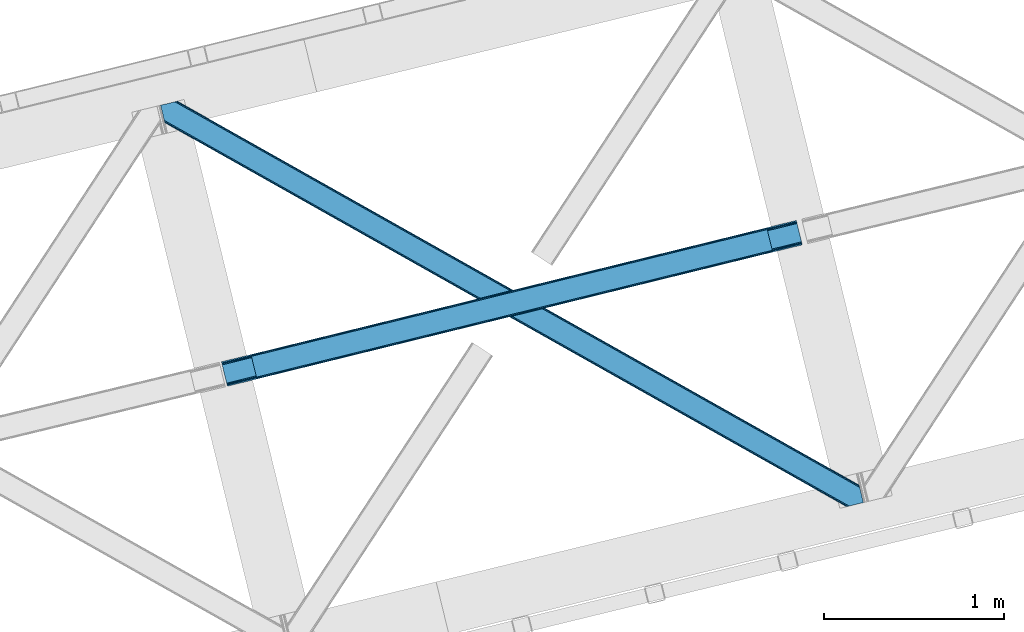
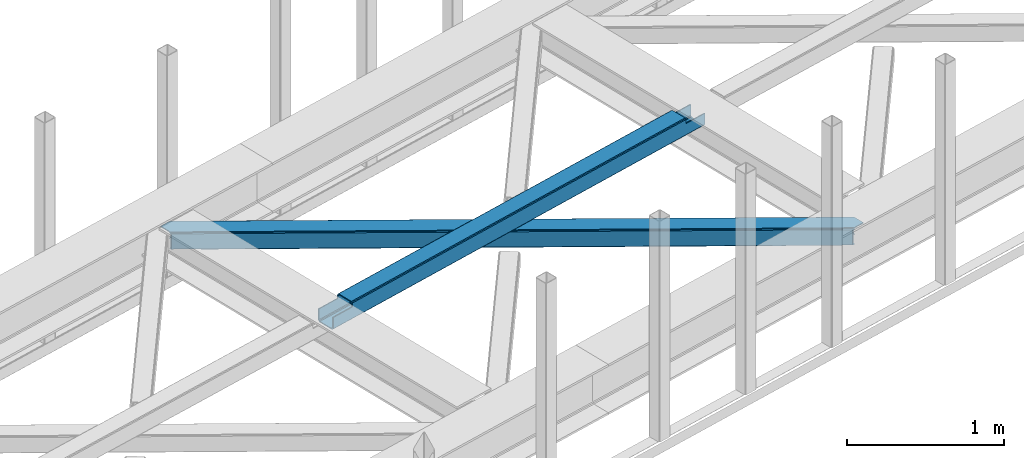
# One storey, part 30 of 66: 1 beam, 1 member.
"""IFC4 building model written with IfcOpenShell, lengths in millimetres."""

from ifc_helpers import new_model, entity, si_unit, converted_unit, derived_unit, direction, frame, origin, place, context, subcontext, project, spatial, triangles, polygons, material, type_object, element, save


model = new_model("IFC4")

# Units and contexts
model_context = context("Model", 3, precision=0.01, world=origin(), true_north=direction((6.12303176911189e-17, 1.0)))
plan_context = context("Plan", 3, precision=0.01, world=origin(), true_north=direction((6.12303176911189e-17, 1.0)))
body_context = subcontext(model_context, "Body", "Model", "MODEL_VIEW")
ifc_project = project(units=[si_unit("LENGTHUNIT", "METRE", prefix="MILLI"), si_unit("AREAUNIT", "SQUARE_METRE"), si_unit("VOLUMEUNIT", "CUBIC_METRE"), converted_unit("PLANEANGLEUNIT", "DEGREE", entity("IfcRatioMeasure", 0.0174532925199433), si_unit("PLANEANGLEUNIT", "RADIAN"), dimensions=[0, 0, 0, 0, 0, 0, 0]), si_unit("MASSUNIT", "GRAM", prefix="KILO"), derived_unit("MASSDENSITYUNIT", [(si_unit("MASSUNIT", "GRAM", prefix="KILO"), 1), (si_unit("LENGTHUNIT", "METRE"), -3)]), derived_unit("MOMENTOFINERTIAUNIT", [(si_unit("LENGTHUNIT", "METRE"), 4)]), si_unit("TIMEUNIT", "SECOND"), si_unit("FREQUENCYUNIT", "HERTZ"), si_unit("THERMODYNAMICTEMPERATUREUNIT", "DEGREE_CELSIUS"), derived_unit("THERMALTRANSMITTANCEUNIT", [(si_unit("MASSUNIT", "GRAM", prefix="KILO"), 1), (si_unit("THERMODYNAMICTEMPERATUREUNIT", "KELVIN"), -1), (si_unit("TIMEUNIT", "SECOND"), -3)]), derived_unit("VOLUMETRICFLOWRATEUNIT", [(si_unit("LENGTHUNIT", "METRE"), 3), (si_unit("TIMEUNIT", "SECOND"), -1)]), derived_unit("MASSFLOWRATEUNIT", [(si_unit("MASSUNIT", "GRAM", prefix="KILO"), 1), (si_unit("TIMEUNIT", "SECOND"), -1)]), derived_unit("ROTATIONALFREQUENCYUNIT", [(si_unit("TIMEUNIT", "SECOND"), -1)]), si_unit("ELECTRICCURRENTUNIT", "AMPERE"), si_unit("ELECTRICVOLTAGEUNIT", "VOLT"), si_unit("POWERUNIT", "WATT"), si_unit("FORCEUNIT", "NEWTON", prefix="KILO"), si_unit("ILLUMINANCEUNIT", "LUX"), si_unit("LUMINOUSFLUXUNIT", "LUMEN"), si_unit("LUMINOUSINTENSITYUNIT", "CANDELA"), derived_unit("USERDEFINED", [(si_unit("MASSUNIT", "GRAM", prefix="KILO"), -1), (si_unit("LENGTHUNIT", "METRE"), -2), (si_unit("TIMEUNIT", "SECOND"), 3), (si_unit("LUMINOUSFLUXUNIT", "LUMEN"), 1)]), derived_unit("LINEARVELOCITYUNIT", [(si_unit("LENGTHUNIT", "METRE"), 1), (si_unit("TIMEUNIT", "SECOND"), -1)]), si_unit("PRESSUREUNIT", "PASCAL"), derived_unit("USERDEFINED", [(si_unit("LENGTHUNIT", "METRE"), -2), (si_unit("MASSUNIT", "GRAM", prefix="KILO"), 1), (si_unit("TIMEUNIT", "SECOND"), -2)]), derived_unit("LINEARFORCEUNIT", [(si_unit("MASSUNIT", "GRAM", prefix="KILO"), 1), (si_unit("LENGTHUNIT", "METRE"), 1), (si_unit("TIMEUNIT", "SECOND"), -2), (si_unit("LENGTHUNIT", "METRE"), -1)]), derived_unit("PLANARFORCEUNIT", [(si_unit("MASSUNIT", "GRAM", prefix="KILO"), 1), (si_unit("LENGTHUNIT", "METRE"), 1), (si_unit("TIMEUNIT", "SECOND"), -2), (si_unit("LENGTHUNIT", "METRE"), -2)])], contexts=[model_context, plan_context])

# Site, building, storey
site_placement = place(None, origin())
site = spatial("IfcSite", under=ifc_project, at=site_placement, CompositionType="ELEMENT")
building_placement = place(site_placement, origin())
building = spatial("IfcBuilding", under=site, at=building_placement, CompositionType="ELEMENT")
storey_placement = place(building_placement, frame((0.0, 0.0, 19800.0)))
storey = spatial("IfcBuildingStorey", under=building, at=storey_placement, Name="06", CompositionType="ELEMENT", Elevation=19800.0)

# Beam
ifc_material = material(Name="Metal painted (White)")
beam_type = type_object("IfcBeamType", PredefinedType="BEAM")
beam_placement = place(storey_placement, frame((-42582.6, 8753.05, 3967.02)))
element("IfcBeam", 1, at=beam_placement, inside=storey, type_object=beam_type, material=ifc_material, ObjectType="Steel Beam", PredefinedType="BEAM", context=body_context, shape_type="Tessellation", body=[
    polygons([(195.608367476555, 47.1603367907862, 116.426112013184), (195.292888840642, 48.4545519431655, 123.123071565755), (3059.93715946748, 752.952673698146, 122.247211281438), (3060.2526381034, 751.658458545759, 115.550251728867), (194.394481695369, 52.1401648754784, 128.800478116566), (3059.03875232221, 756.63828663046, 127.92461783224), (193.049920384546, 57.6560744289323, 132.593997984055), (3057.69419101138, 762.154196183919, 131.718137699738), (191.463902179238, 64.1625333758854, 133.926102156763), (3056.10817280608, 768.660655130851, 133.050241872438), (169.91268263321, 152.573955618372, 133.926046892466), (3034.55695326005, 857.072077373337, 133.05018660814), (168.326664427911, 159.080414565288, 132.593934585632), (3032.97093505476, 863.578536320267, 131.718074301311), (166.982103117088, 164.596324118746, 128.800407822355), (3031.62637374393, 869.094445873725, 127.924547538033), (166.083695971823, 168.281937051061, 123.12299666394), (3030.72796659867, 872.78005880604, 122.247136379614), (165.768217335893, 169.576152203463, 116.426035493392), (3030.41248796274, 874.074273958432, 115.550175209066), (3028.75470184381, 880.875152592466, 100.498256633611), (3028.75470184381, 880.875152592468, 122.550171266493), (3029.07018047973, 879.580937440089, 129.24713243705), (3029.968587625, 875.895324507774, 134.924543595464), (3031.31314893582, 870.379414954318, 138.718070358737), (3032.89916714112, 863.872956007376, 140.050182665567), (3057.76595892501, 761.859776496813, 140.050246432065), (3059.3519771303, 755.353317549901, 138.718142259361), (3060.69653844113, 749.837407996445, 134.924622391867), (3061.59494558639, 746.151795064129, 129.247215841061), (3061.91042422235, 744.857579911637, 122.55025628849), (3061.91042422232, 744.857579911717, 100.498256633611), (3060.2526381034, 751.658458545755, 100.498256633611), (3030.41248796274, 874.074273958429, 100.498256633611), (165.768217335893, 169.576152203463, 101.478032742183), (195.608367476546, 47.1603367907873, 101.478032742183), (197.266153595643, 40.3594581560808, 101.478032742183), (197.266153595478, 40.3594581567511, 123.426116572816), (196.950674959548, 41.6536733091445, 130.123076125387), (196.052267814283, 45.3392862414595, 135.800482676189), (194.707706503452, 50.8551957949178, 139.594002543682), (193.121688298162, 57.361654741847, 140.926106716386), (168.254896514278, 159.374834252409, 140.926042949888), (166.668878308987, 165.881293199339, 139.593930643059), (165.324316998156, 171.397202752797, 135.800403879781), (164.425909852882, 175.082815685111, 130.122992721366), (164.110431216969, 176.377030837501, 123.426031550818), (164.110431216961, 176.377030837499, 101.478032742183), (3224.36306932035, 792.017916694966, 99.4982566336028), (3224.36306932034, 792.017916694964, 24.5000712229983), (31.4979362596031, 6.80087864157621, 25.4762844973403), (31.4979362596031, 6.80087864157838, 100.478032742175), (194.637299836219, 46.9215234289606, 100.478032742183), (1.65778611894061, 129.216694054251, 25.4762079775439), (3194.52291917968, 914.433732107637, 24.4999947032018), (3194.52291917969, 914.43373210764, 99.4982566336028), (3031.38355560307, 874.313087320258, 99.4982566336115), (1.65778611894061, 129.216694054253, 100.478032742179), (3226.02085543916, 785.217038061375, 17.5000751655718), (3226.02085543927, 785.217038060912, 99.4982566336028), (3062.88149186268, 745.096393273461, 99.4982566336071), (33.1557223796959, 2.71258215889247e-09, 100.478032742175), (33.1557223787603, 6.59790941881511e-09, 18.4762884399095), (3192.86513306077, 921.234610741677, 99.4982566336028), (3192.86513306076, 921.234610741675, 17.4999901435748), (1.73258740687743e-11, 136.017572688288, 18.4762034179168), (1.73258740687743e-11, 136.017572688289, 100.478032742175), (163.139363576634, 176.138217475671, 100.478032742183), (3061.22370574374, 751.897271907586, 99.4982566336028), (3029.72576948415, 881.113965954297, 99.4982566336071), (3194.83839781561, 913.139516955241, 17.8030351506349), (3195.73680496087, 909.453904022926, 12.1256285998286), (3197.0813662717, 903.93799446947, 8.33210873233546), (3198.66738447699, 897.43153552254, 7.00000455963569), (3220.21860402303, 809.020113280054, 7.00005982392856), (3221.80462222832, 802.513654333124, 8.33217213075803), (3223.14918353915, 796.997744779667, 12.1256988940357), (3224.04759068442, 793.31213184735, 17.8031100524503), (3225.70537680334, 786.511253213297, 10.8031139950195), (3224.80696965809, 790.19686614561, 5.12570283660054), (3223.46240834725, 795.712775699067, 1.33217607332724), (3221.87639014196, 802.219234646016, 6.37665021031353e-05), (3197.00959835807, 904.232414156576, 4.33146851719357e-12), (3195.42358015278, 910.738873103494, 1.3321041727041), (3194.07901884195, 916.254782656952, 5.12562404019723), (3193.18061169669, 919.940395589265, 10.8030305909992), (196.295085955143, 40.1206447949233, 100.478032742179), (164.797149695557, 169.337338841635, 100.478032742179), (27.3534709622775, 23.8030752266689, 7.97627309827059), (28.9394891675764, 17.2966162797201, 9.30838540509573), (30.2840504784081, 11.780706726263, 13.101912168369), (31.1824576236816, 8.09509379395009, 18.7793233267793), (1.97326475486207, 127.922478901843, 18.779248424964), (2.87167190013556, 124.236865969529, 13.1018418741663), (4.21623321095863, 118.72095641607, 9.30832200667315), (5.80225141624883, 112.214497469155, 7.97621783397339), (0.315478635930117, 134.723357535894, 11.7792438653456), (1.21388578120361, 131.037744603581, 6.10183731454358), (2.55844709203534, 125.521835050121, 2.30831744704612), (4.14446529732554, 119.015376103192, 0.976213274346355), (29.0112570812095, 17.0021965926294, 0.976277040844127), (30.5972752865084, 10.4957376456991, 2.3083893476736), (31.9418365973314, 4.97982809224191, 6.1019161109469), (32.8402437426049, 1.29421515992579, 11.7793272693615)], [[[1, 2, 3, 4]], [[2, 5, 6, 3]], [[5, 7, 8, 6]], [[7, 9, 10, 8]], [[11, 12, 10, 9]], [[11, 13, 14, 12]], [[13, 15, 16, 14]], [[15, 17, 18, 16]], [[17, 19, 20, 18]], [[21, 22, 23, 24, 25, 26, 27, 28, 29, 30, 31, 32, 33, 4, 3, 6, 8, 10, 12, 14, 16, 18, 20, 34]], [[35, 19, 17, 15, 13, 11, 9, 7, 5, 2, 1, 36, 37, 38, 39, 40, 41, 42, 43, 44, 45, 46, 47, 48]], [[42, 41, 28, 27]], [[41, 40, 29, 28]], [[40, 39, 30, 29]], [[39, 38, 31, 30]], [[27, 26, 43, 42]], [[47, 46, 23, 22]], [[46, 45, 24, 23]], [[45, 44, 25, 24]], [[44, 43, 26, 25]], [[33, 49, 50, 51, 52, 53, 1, 4]], [[54, 55, 56, 57, 20, 19, 35, 58]], [[59, 60, 61, 31, 38, 37, 62, 63]], [[64, 65, 66, 67, 68, 47, 22, 21]], [[61, 60, 49, 69]], [[64, 70, 57, 56]], [[65, 64, 56, 55, 71, 72, 73, 74, 75, 76, 77, 78, 50, 49, 60, 59, 79, 80, 81, 82, 83, 84, 85, 86]], [[87, 53, 52, 62]], [[67, 58, 88, 68]], [[89, 90, 76, 75]], [[90, 91, 77, 76]], [[91, 92, 78, 77]], [[92, 51, 50, 78]], [[54, 93, 71, 55]], [[93, 94, 72, 71]], [[94, 95, 73, 72]], [[95, 96, 74, 73]], [[89, 75, 74, 96]], [[66, 97, 98, 99, 100, 101, 102, 103, 104, 63, 62, 52, 51, 92, 91, 90, 89, 96, 95, 94, 93, 54, 58, 67]], [[63, 104, 79, 59]], [[104, 103, 80, 79]], [[103, 102, 81, 80]], [[102, 101, 82, 81]], [[100, 99, 84, 83]], [[99, 98, 85, 84]], [[98, 97, 86, 85]], [[97, 66, 65, 86]], [[83, 82, 101, 100]]], closed=False),
])

# Member
member_type = type_object("IfcMemberType", PredefinedType="BRACE")
member_placement = place(storey_placement, frame((-42920.63, 8084.0, 3824.0)))
element("IfcMember", 2, at=member_placement, inside=storey, type_object=member_type, ObjectType="Steel Horizontal Brace", PredefinedType="BRACE", context=body_context, shape_type="Tessellation", body=[
    triangles([(3809.33492431641, 0.0, 122.499499511719), (3811.23248291016, 0.462181091308594, 129.196765136719), (23.4543823242202, 2133.54884033203, 129.196765136719), (23.8869140625029, 2131.77569274902, 122.499499511719), (3816.62750244141, 1.7772171020506, 134.87548828125), (22.2265502929731, 2138.59504394531, 134.87548828125), (3824.70142822266, 3.74570159912037, 138.668280029298), (20.3848022460952, 2146.14690856934, 138.668280029298), (3834.22642822266, 6.06765289306622, 140.00075683594), (18.2128417968779, 2155.05566711426, 140.00075683594), (1916.9806640625, 1065.68204498291, 17.5012573242202), (2556.11374511719, 705.753433227539, 17.5012573242202), (3195.25147705078, 345.824821472168, 17.5012573242202), (3809.33492431641, 0.0, 17.5012573242202), (1277.84293212891, 1425.61123809814, 17.5012573242202), (638.709851074222, 1785.53984985352, 17.5012573242202), (23.8869140625029, 2131.77569274902, 17.5012573242202), (3885.455859375, 97.7219421386717, 140.00075683594), (3903.67335205078, 22.9956893920898, 140.00075683594), (69.4422729492217, 2246.71053771973, 140.00075683594), (0.0, 2229.7825012207, 140.00075683594), (3883.28854980469, 106.630700683593, 138.668280029298), (78.9672729492231, 2249.03248901367, 138.668280029298), (3881.44680175782, 114.183146667479, 134.87548828125), (87.0458496093779, 2251.00097351074, 134.87548828125), (3880.21431884766, 119.229931640624, 129.196765136719), (92.4408691406279, 2252.31600952148, 129.196765136719), (3879.78178710938, 121.001916503907, 122.499499511719), (94.3337768554702, 2252.77760925293, 122.499499511719), (3265.41463623047, 466.983123779297, 17.5012573242202), (3879.78178710938, 121.001916503907, 17.5012573242202), (2626.2908569336, 826.905921936035, 17.5012573242202), (1987.16707763672, 1186.82872009277, 17.5012573242202), (708.919519042975, 1906.67431640625, 17.5012573242202), (94.3337768554702, 2252.77760925293, 17.5012573242202), (1348.04329833985, 1546.75151824951, 17.5012573242202), (82.4833374023438, 2249.88941345215, 122.197192382813), (69.0143920898481, 2246.60589294434, 131.668707275392), (59.4893920898467, 2244.28394165039, 133.001184082033), (0.0, 2229.7825012207, 133.001184082033), (77.0883178710938, 2248.57437744141, 127.873590087893), (84.3808959960952, 2250.35101318359, 24.5008300781265), (77.0883178710938, 2248.57437744141, 12.1248413085959), (91.5804565429717, 2252.1067199707, 9.49942016601563), (82.4833374023438, 2249.88941345215, 17.8035644531265), (84.3808959960952, 2250.35101318359, 115.499926757813), (72.3072143554746, 2247.40933227539, 9.49942016601563), (92.0548461914077, 2252.22182922363, 10.8691040039084), (1983.48823242188, 1180.86745605469, 24.5008300781265), (3882.05141601563, 111.689694213866, 115.499926757813), (2626.78850097657, 818.593638610839, 24.5008300781265), (3270.08411865235, 456.319239807128, 24.5008300781265), (3882.05141601563, 111.689694213866, 24.5008300781265), (1340.18796386719, 1543.1418548584, 24.5008300781265), (696.8876953125, 1905.41625366211, 24.5008300781265), (3882.48394775391, 109.917709350586, 122.197192382813), (3883.71643066406, 104.871505737305, 127.873590087893), (3885.55817871094, 97.3190597534176, 131.668707275392), (3887.73013916016, 88.4097198486324, 133.001184082033), (3883.71643066406, 104.871505737305, 12.1248413085959), (3885.41400146484, 97.9004196166989, 8.52041015625218), (3880.58638916016, 117.703280639647, 8.52041015625218), (3903.67335205078, 22.9956893920898, 133.001184082033), (3882.48394775391, 109.917709350586, 17.8035644531265), (3880.37244873047, 118.591017150879, 10.9365417480476), (3844.18395996094, 8.49483032226544, 133.001184082033), (15.9432128906265, 2164.3678894043, 133.001184082033), (3834.65895996094, 6.17287902831958, 131.668707275392), (18.1151733398438, 2155.45913085938, 131.668707275392), (3826.58503417969, 4.20439453124982, 127.873590087893), (19.9569213867217, 2147.90610351562, 127.873590087893), (3821.19001464844, 2.88935852050781, 122.197192382813), (21.1847534179688, 2142.85989990234, 122.197192382813), (3819.29245605469, 2.42717742919922, 115.499926757813), (21.6172851562515, 2141.08791503906, 115.499926757813), (3208.50183105469, 346.396298217773, 24.5008300781265), (3819.29245605469, 2.42717742919922, 24.5008300781265), (2565.16435546875, 708.691044616698, 24.5008300781265), (1921.82687988281, 1070.98579101562, 24.5008300781265), (635.15192871094, 1795.5764465332, 24.5008300781265), (21.6172851562515, 2141.08791503906, 24.5008300781265), (1278.48940429688, 1433.28111877441, 24.5008300781265), (21.1847534179688, 2142.85989990234, 17.8035644531265), (23.2590454101592, 2134.35111694336, 9.49942016601563), (19.9569213867217, 2147.90610351562, 12.1248413085959), (23.3660156250044, 2133.91044616699, 10.8691040039084), (18.8686157226621, 2152.37676086426, 9.49942016601563), (3826.58503417969, 4.20439453124982, 12.1248413085959), (3812.86494140625, 0.859831237792605, 8.52041015625218), (3821.19001464844, 2.88935852050781, 17.8035644531265), (3834.0357421875, 6.02114410400372, 8.52041015625218), (3811.91616210938, 0.628450012206486, 10.9365417480476), (190.667431640628, 2055.62801513672, 9.49942016601563), (195.062512207034, 2037.60237121582, 9.49942016601563), (196.071752929689, 2037.66980895996, 8.49948120117188), (196.053149414067, 2037.42447509766, 8.8831787109375), (191.290649414063, 2056.67213745117, 8.85294799804615), (195.732238769531, 2037.48261108398, 9.08316650390771), (191.346459960943, 2055.82684020996, 9.20641479492406), (195.383422851563, 2037.54423522949, 9.29943237304906), (191.006945800786, 2055.72684631348, 9.35291748046802), (191.234838867189, 2057.51743469238, 8.49948120117188), (150.916369628911, 2218.69131774902, 9.49942016601563), (155.311450195317, 2200.66567382813, 9.49942016601563), (151.251232910159, 2218.34947814941, 9.25757446289208), (155.809094238284, 2200.23779296875, 9.42500610351635), (151.604699707037, 2217.985546875, 8.99945068359375), (156.246276855469, 2199.30529174805, 9.11804809570458), (151.958166503908, 2217.62045288086, 8.74132690429906), (156.692761230472, 2198.36465148926, 8.80643920898365), (152.293029785156, 2217.27977600098, 8.49948120117188), (157.129943847656, 2197.43215026855, 8.49948120117188), (3713.61518554688, 194.650328063964, 8.52041015625218), (3708.78757324219, 214.453189086913, 8.52041015625218), (3713.26636962891, 194.529986572265, 8.40181274414135), (3708.39689941407, 214.57120513916, 8.37390747070458), (3713.06173095704, 194.460804748534, 8.3320495605476), (3708.00157470704, 214.689802551269, 8.22740478515698), (3707.90390625, 214.478187561035, 7.87393798828271), (3713.112890625, 193.950370788574, 8.19484863281468), (3707.80623779297, 214.266572570801, 7.52047119140843), (3713.23846435547, 192.706260681152, 7.85765991211156), (3713.36403808594, 191.465638732911, 7.52047119140843), (3264.7635131836, 465.822729492187, 10.8039916992202), (3262.9031616211, 462.51711730957, 5.12526855468968), (3260.11728515625, 457.57032623291, 1.33247680664135), (3708.57828369141, 211.088859558105, 5.59500732422021), (708.2683959961, 1905.51392211914, 10.8039916992202), (706.40339355469, 1902.20830993652, 5.12526855468968), (153.144140625001, 2213.77533874512, 5.12526855468968), (703.61751708985, 1897.2609375, 1.33247680664135), (154.985888671879, 2206.22347412109, 1.33247680664135), (700.333996582034, 1891.42524719238, 0.0), (157.157849121097, 2197.31471557617, 0.0), (3710.29445800782, 204.05207977295, 1.33247680664135), (3712.46641845704, 195.143321228026, 0.0), (3256.82911376953, 451.735217285155, 0.0), (2625.63973388672, 825.744946289062, 10.8039916992202), (1986.51595458985, 1185.6677444458, 10.8039916992202), (1347.38752441407, 1545.59054260254, 10.8039916992202), (2623.77938232422, 822.439915466308, 5.12526855468968), (1984.65560302735, 1182.36271362305, 5.12526855468968), (1345.52717285157, 1542.28493041992, 5.12526855468968), (2620.98885498047, 817.492543029784, 1.33247680664135), (1981.8697265625, 1177.41534118652, 1.33247680664135), (1342.74129638672, 1537.33813934326, 1.33247680664135), (2617.70533447266, 811.657434082032, 0.0), (1978.58155517578, 1171.58023223877, 0.0), (1339.45777587891, 1531.50303039551, 0.0), (3746.51550292969, 55.464056396484, 0.0), (3203.83699951172, 361.072727966308, 0.0), (2564.69926757813, 721.001921081543, 0.0), (1925.56618652344, 1080.93053283691, 0.0), (1286.43310546875, 1440.85914459228, 0.0), (647.295373535162, 1800.78775634766, 0.0), (191.206933593756, 2057.63486938476, 0.0), (3195.90260009766, 346.985215759278, 10.8039916992202), (639.360974121097, 1786.70024414062, 10.8039916992202), (641.225976562506, 1790.00585632324, 5.12526855468968), (195.220642089844, 2041.17308349609, 5.12526855468968), (3197.76295166016, 350.290827941893, 5.12526855468968), (3200.548828125, 355.237619018555, 1.33247680664135), (3748.68746337891, 46.5552978515625, 1.33247680664135), (3752.58024902344, 34.810665893554, 8.52041015625218), (3750.40363769532, 39.5190994262693, 5.59500732422021), (3751.17568359376, 36.3408050537109, 7.52047119140843), (3752.23608398438, 35.1809921264648, 8.278564453125), (644.011853027347, 1794.95206604004, 1.33247680664135), (193.378894042973, 2048.72611083984, 1.33247680664135), (2561.41574707031, 715.166812133788, 1.33247680664135), (1922.27801513672, 1075.0948425293, 1.33247680664135), (1283.14493408203, 1435.02403564453, 1.33247680664135), (2558.62987060547, 710.219439697265, 5.12526855468968), (1919.49678955079, 1070.1486328125, 5.12526855468968), (1280.35905761719, 1430.07666320801, 5.12526855468968), (2556.76951904297, 706.914408874511, 10.8039916992202), (1917.63178710938, 1066.84243927002, 10.8039916992202), (1278.49870605469, 1426.77163238525, 10.8039916992202), (3745.61788330079, 59.1423202514643, 7.52047119140843), (3746.13413085938, 57.3435928344725, 7.90416870117406), (3746.6689819336, 56.4360900878901, 8.10880737304615), (3747.30150146485, 55.3774337768555, 8.34832763671875), (3747.75263671875, 54.6135269165034, 8.52041015625218), (3211.01795654297, 350.8623046875, 12.1248413085959), (3217.08735351563, 361.644786071776, 6.99957275390625), (3213.79918212891, 355.80909576416, 8.3320495605476), (3744.24587402344, 64.7762786865233, 6.99957275390625), (643.742102050783, 1810.82435302734, 6.99957275390625), (188.937304687504, 2066.94709167481, 6.99957275390625), (637.668054199225, 1800.04245300293, 12.1248413085959), (640.453930664065, 1804.98866271973, 8.3320495605476), (635.807702636725, 1796.73684082031, 17.8035644531265), (3209.15295410156, 347.556692504882, 17.8035644531265), (2565.81547851563, 709.851438903808, 17.8035644531265), (1922.4826538086, 1072.1467666626, 17.8035644531265), (1279.14517822266, 1434.44209442139, 17.8035644531265), (2567.68048095703, 713.157632446289, 12.1248413085959), (1924.3430053711, 1075.45237884522, 12.1248413085959), (1281.00552978516, 1437.74712524414, 12.1248413085959), (2570.46635742188, 718.104423522949, 8.3320495605476), (1927.12888183594, 1080.39916992188, 8.3320495605476), (1283.79140625001, 1442.6939163208, 8.3320495605476), (2573.74987792969, 723.939532470702, 6.99957275390625), (1930.41240234375, 1086.23427886963, 6.99957275390625), (1287.07492675781, 1448.52960662842, 6.99957275390625), (694.371569824223, 1900.95024719238, 12.1248413085959), (691.585693359375, 1896.00287475586, 8.3320495605476), (157.264819335942, 2196.88567199707, 8.41343994140698), (159.427478027348, 2188.00249328613, 6.99957275390625), (3261.49859619141, 441.071333312988, 6.99957275390625), (3264.78676757813, 446.906442260743, 8.3320495605476), (3714.73604736329, 185.831680297852, 6.99957275390625), (3267.57264404297, 451.853814697266, 12.1248413085959), (688.302172851567, 1890.16718444824, 6.99957275390625), (696.236572265625, 1904.25469665527, 17.8035644531265), (3269.43299560547, 455.15884552002, 17.8035644531265), (2621.48649902344, 809.18025970459, 8.3320495605476), (2618.19832763672, 803.345150756835, 6.99957275390625), (1978.18623046875, 1171.4546585083, 8.3320495605476), (1974.90270996094, 1165.61954956055, 6.99957275390625), (1331.59779052735, 1527.89336700439, 6.99957275390625), (1334.88596191406, 1533.72847595215, 8.3320495605476), (2624.27237548828, 814.127632141113, 12.1248413085959), (1980.97210693359, 1176.40203094482, 12.1248413085959), (1337.67183837891, 1538.67584838867, 12.1248413085959), (2626.13272705078, 817.432662963867, 17.8035644531265), (1982.83245849609, 1179.70706176758, 17.8035644531265), (1339.53218994141, 1541.98087921143, 17.8035644531265)], [[1, 2, 3], [3, 4, 1], [2, 5, 6], [6, 3, 2], [5, 7, 8], [8, 6, 5], [7, 9, 10], [10, 8, 7], [11, 1, 4], [1, 12, 13], [11, 12, 1], [13, 14, 1], [15, 4, 16], [4, 15, 11], [17, 16, 4], [9, 18, 10], [9, 19, 18], [20, 10, 18], [21, 10, 20], [18, 22, 23], [23, 20, 18], [22, 24, 25], [25, 23, 22], [24, 26, 27], [27, 25, 24], [26, 28, 29], [29, 27, 26], [30, 28, 31], [28, 30, 32], [28, 33, 29], [33, 28, 32], [34, 35, 29], [36, 29, 33], [29, 36, 34], [37, 29, 27], [38, 23, 20], [21, 39, 20], [39, 21, 40], [39, 38, 20], [41, 23, 38], [41, 37, 25], [25, 23, 41], [27, 25, 37], [42, 35, 29], [43, 44, 45], [37, 46, 29], [43, 47, 44], [42, 45, 35], [46, 42, 29], [48, 35, 45], [45, 44, 48], [49, 50, 46], [50, 51, 52], [49, 51, 50], [52, 53, 50], [54, 46, 55], [46, 54, 49], [42, 55, 46], [50, 56, 46], [37, 46, 56], [56, 57, 37], [41, 37, 57], [57, 58, 41], [38, 41, 58], [58, 59, 38], [39, 38, 59], [57, 24, 22], [60, 61, 62], [24, 57, 56], [58, 57, 22], [58, 18, 59], [19, 59, 18], [59, 19, 63], [58, 22, 18], [31, 28, 53], [62, 64, 60], [64, 31, 53], [65, 64, 62], [65, 31, 64], [28, 50, 53], [56, 26, 24], [28, 26, 56], [50, 28, 56], [59, 66, 67], [66, 59, 63], [67, 39, 59], [40, 39, 67], [66, 68, 67], [69, 67, 68], [68, 70, 69], [71, 69, 70], [70, 72, 71], [73, 71, 72], [72, 74, 73], [75, 73, 74], [76, 74, 77], [74, 76, 78], [74, 79, 75], [79, 74, 78], [80, 81, 75], [82, 75, 79], [75, 82, 80], [83, 84, 85], [81, 4, 17], [17, 86, 83], [86, 84, 83], [83, 81, 17], [75, 4, 81], [73, 71, 6], [3, 73, 6], [3, 4, 73], [75, 73, 4], [71, 8, 6], [69, 8, 71], [87, 85, 84], [69, 67, 10], [69, 10, 8], [67, 21, 10], [67, 40, 21], [72, 1, 2], [68, 7, 9], [19, 66, 9], [66, 19, 63], [66, 68, 9], [70, 7, 68], [70, 72, 5], [5, 7, 70], [2, 5, 72], [77, 14, 1], [88, 89, 90], [72, 74, 1], [88, 91, 89], [77, 90, 14], [74, 77, 1], [92, 14, 90], [90, 89, 92], [93, 94, 84], [84, 87, 93], [95, 96, 97], [96, 98, 99], [99, 98, 100], [101, 100, 94], [94, 93, 101], [100, 101, 99], [99, 97, 96], [97, 102, 95], [103, 104, 44], [47, 44, 104], [105, 106, 104], [107, 108, 106], [109, 110, 108], [111, 112, 110], [110, 109, 111], [108, 107, 109], [106, 105, 107], [104, 103, 105], [62, 61, 113], [113, 114, 62], [115, 116, 114], [117, 118, 116], [116, 115, 117], [119, 118, 120], [121, 119, 122], [122, 123, 121], [120, 122, 119], [117, 120, 118], [114, 113, 115], [124, 30, 31], [125, 124, 118], [118, 119, 125], [119, 121, 125], [124, 65, 114], [114, 116, 124], [116, 118, 124], [65, 62, 114], [126, 125, 127], [48, 128, 103], [128, 129, 130], [130, 111, 128], [128, 109, 107], [109, 128, 111], [128, 105, 103], [105, 128, 107], [128, 48, 35], [35, 34, 128], [103, 44, 48], [129, 131, 132], [132, 130, 129], [131, 133, 134], [134, 132, 131], [135, 136, 137], [137, 126, 135], [127, 135, 126], [121, 127, 125], [31, 65, 124], [30, 124, 138], [138, 32, 30], [32, 138, 139], [139, 33, 32], [33, 139, 36], [140, 36, 139], [36, 140, 34], [128, 34, 140], [124, 125, 138], [141, 138, 125], [138, 141, 139], [142, 139, 141], [139, 142, 143], [143, 140, 139], [140, 143, 129], [129, 128, 140], [125, 126, 141], [144, 141, 126], [141, 144, 145], [145, 142, 141], [142, 145, 146], [146, 143, 142], [143, 146, 129], [131, 129, 146], [126, 137, 147], [147, 144, 126], [144, 147, 148], [148, 145, 144], [145, 148, 146], [149, 146, 148], [146, 149, 133], [133, 131, 146], [136, 150, 151], [137, 151, 147], [151, 137, 136], [148, 152, 153], [152, 147, 151], [148, 147, 152], [133, 149, 154], [153, 149, 148], [149, 153, 154], [155, 133, 154], [156, 133, 155], [134, 133, 156], [157, 92, 14], [158, 16, 17], [159, 96, 95], [158, 86, 94], [94, 159, 158], [94, 98, 159], [86, 84, 94], [95, 160, 159], [161, 162, 163], [92, 157, 164], [157, 161, 165], [165, 166, 157], [167, 164, 157], [157, 166, 167], [164, 89, 92], [163, 165, 161], [150, 163, 162], [162, 151, 150], [155, 168, 169], [169, 156, 155], [168, 159, 160], [160, 169, 168], [17, 86, 158], [14, 13, 157], [151, 162, 152], [170, 152, 162], [152, 170, 153], [171, 153, 170], [153, 171, 172], [172, 154, 153], [154, 172, 168], [168, 155, 154], [162, 161, 173], [173, 170, 162], [170, 173, 174], [174, 171, 170], [171, 174, 175], [175, 172, 171], [172, 175, 168], [159, 168, 175], [161, 157, 176], [176, 173, 161], [173, 176, 177], [177, 174, 173], [174, 177, 175], [178, 175, 177], [175, 178, 159], [158, 159, 178], [157, 13, 176], [12, 176, 13], [176, 12, 11], [11, 177, 176], [177, 11, 15], [15, 178, 177], [178, 15, 16], [16, 158, 178], [166, 179, 180], [166, 180, 181], [167, 181, 182], [167, 182, 183], [91, 89, 183], [164, 183, 89], [184, 183, 182], [88, 91, 183], [183, 184, 88], [185, 180, 179], [182, 185, 186], [182, 181, 185], [180, 185, 181], [179, 187, 185], [188, 189, 102], [93, 85, 190], [93, 87, 85], [102, 190, 191], [190, 102, 97], [97, 99, 190], [80, 192, 81], [83, 81, 192], [192, 190, 83], [85, 83, 190], [102, 191, 188], [182, 186, 184], [90, 88, 184], [184, 193, 90], [77, 90, 193], [193, 76, 77], [76, 193, 78], [194, 78, 193], [78, 194, 79], [195, 79, 194], [79, 195, 82], [196, 82, 195], [82, 196, 80], [192, 80, 196], [193, 184, 197], [197, 194, 193], [194, 197, 198], [198, 195, 194], [195, 198, 199], [199, 196, 195], [196, 199, 190], [190, 192, 196], [184, 186, 200], [200, 197, 184], [197, 200, 201], [201, 198, 197], [198, 201, 202], [202, 199, 198], [199, 202, 190], [191, 190, 202], [186, 185, 200], [203, 200, 185], [200, 203, 201], [204, 201, 203], [201, 204, 202], [205, 202, 204], [202, 205, 191], [188, 191, 205], [206, 106, 108], [108, 207, 206], [108, 110, 207], [110, 208, 207], [104, 206, 43], [43, 47, 104], [207, 208, 209], [210, 123, 122], [122, 211, 210], [122, 117, 211], [210, 212, 123], [213, 211, 117], [61, 60, 113], [213, 113, 60], [209, 214, 207], [206, 215, 45], [45, 43, 206], [215, 55, 42], [42, 45, 215], [64, 53, 216], [52, 216, 53], [60, 64, 213], [216, 213, 64], [210, 211, 217], [217, 218, 210], [218, 217, 219], [219, 220, 218], [220, 219, 221], [222, 221, 219], [221, 222, 214], [207, 214, 222], [211, 213, 223], [223, 217, 211], [217, 223, 224], [224, 219, 217], [219, 224, 225], [225, 222, 219], [222, 225, 207], [206, 207, 225], [213, 216, 223], [226, 223, 216], [223, 226, 224], [227, 224, 226], [224, 227, 228], [228, 225, 224], [225, 228, 215], [215, 206, 225], [216, 52, 51], [51, 226, 216], [226, 51, 49], [49, 227, 226], [227, 49, 228], [54, 228, 49], [228, 54, 215], [55, 215, 54], [209, 134, 189], [132, 208, 130], [208, 132, 134], [130, 208, 111], [134, 209, 208], [189, 134, 156], [169, 102, 156], [102, 169, 160], [156, 102, 189], [160, 95, 102], [136, 212, 187], [123, 127, 121], [136, 123, 212], [123, 135, 127], [123, 136, 135], [150, 136, 187], [179, 150, 187], [165, 179, 166], [179, 163, 150], [179, 165, 163], [203, 185, 210], [210, 218, 203], [218, 204, 203], [204, 218, 220], [185, 212, 210], [185, 187, 212], [214, 188, 221], [188, 214, 189], [209, 189, 214], [205, 221, 188], [220, 205, 204], [221, 205, 220]]),
])

save(model, "model.ifc")
